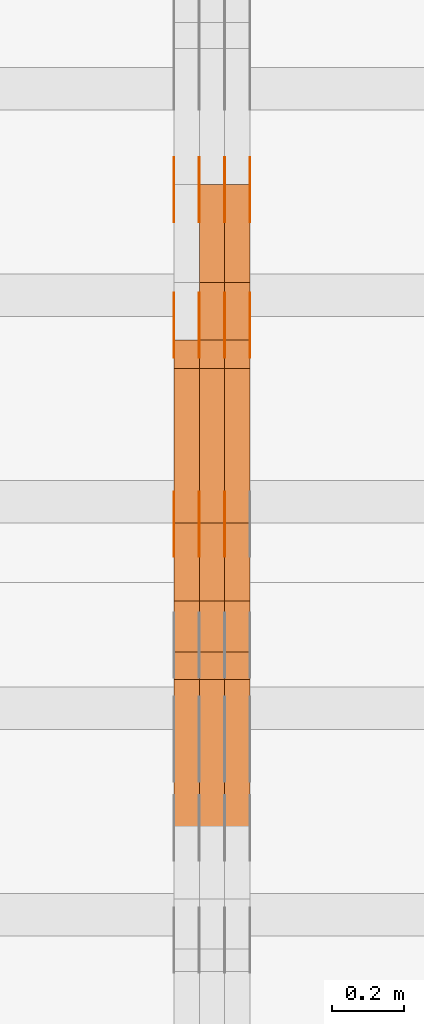
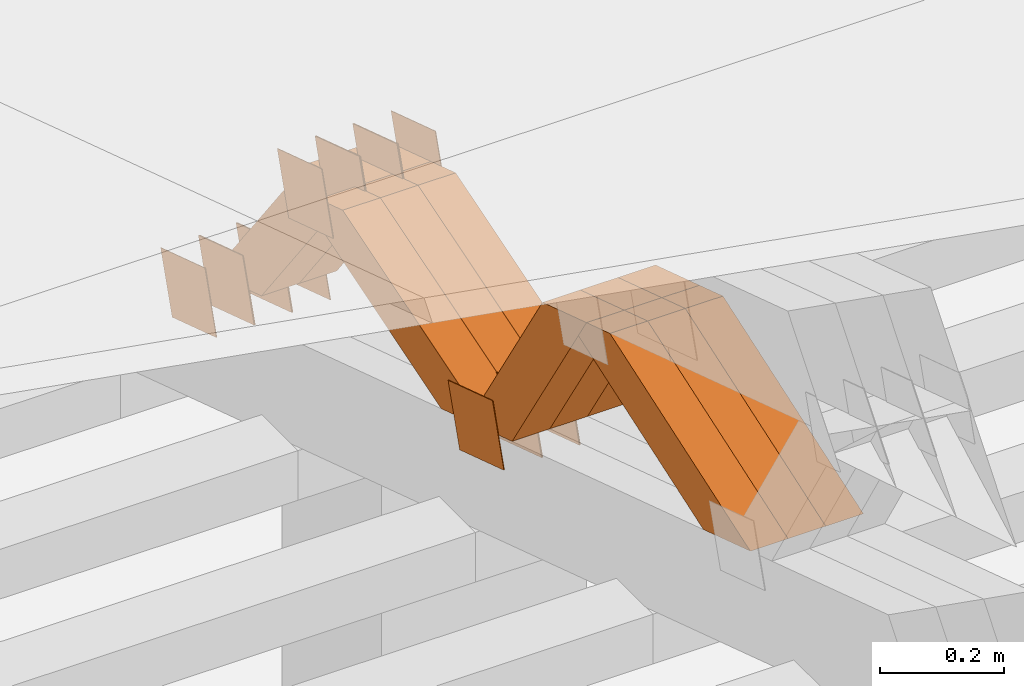
# One storey, part 232 of 385: 28 proxies.
"""IFC2X3 building model written with IfcOpenShell, lengths in millimetres."""

from ifc_helpers import new_model, entity, si_unit, converted_unit, derived_unit, direction, frame, origin, place, context, subcontext, project, spatial, polyline, outline, extrude, source, transform, mapped, material, type_object, type_shapes, element, save


model = new_model("IFC2X3")

# Units and contexts
model_context = context("Model", 3, precision=0.01, world=origin(), true_north=direction((6.12303176911189e-17, 1.0)))
body_context = subcontext(model_context, "Body", "Model", "MODEL_VIEW")
ifc_project = project(units=[si_unit("LENGTHUNIT", "METRE", prefix="MILLI"), si_unit("AREAUNIT", "SQUARE_METRE"), si_unit("VOLUMEUNIT", "CUBIC_METRE"), converted_unit("PLANEANGLEUNIT", "DEGREE", entity("IfcRatioMeasure", 0.0174532925199433), si_unit("PLANEANGLEUNIT", "RADIAN"), dimensions=[0, 0, 0, 0, 0, 0, 0]), si_unit("MASSUNIT", "GRAM", prefix="KILO"), derived_unit("MASSDENSITYUNIT", [(si_unit("MASSUNIT", "GRAM", prefix="KILO"), 1), (si_unit("LENGTHUNIT", "METRE"), -3)]), si_unit("TIMEUNIT", "SECOND"), si_unit("FREQUENCYUNIT", "HERTZ"), si_unit("THERMODYNAMICTEMPERATUREUNIT", "DEGREE_CELSIUS"), derived_unit("THERMALTRANSMITTANCEUNIT", [(si_unit("MASSUNIT", "GRAM", prefix="KILO"), 1), (si_unit("THERMODYNAMICTEMPERATUREUNIT", "KELVIN"), -1), (si_unit("TIMEUNIT", "SECOND"), -3)]), derived_unit("VOLUMETRICFLOWRATEUNIT", [(si_unit("LENGTHUNIT", "METRE"), 3), (si_unit("TIMEUNIT", "SECOND"), -1)]), si_unit("ELECTRICCURRENTUNIT", "AMPERE"), si_unit("ELECTRICVOLTAGEUNIT", "VOLT"), si_unit("POWERUNIT", "WATT"), si_unit("FORCEUNIT", "NEWTON", prefix="KILO"), si_unit("ILLUMINANCEUNIT", "LUX"), si_unit("LUMINOUSFLUXUNIT", "LUMEN"), si_unit("LUMINOUSINTENSITYUNIT", "CANDELA"), derived_unit("USERDEFINED", [(si_unit("MASSUNIT", "GRAM", prefix="KILO"), -1), (si_unit("LENGTHUNIT", "METRE"), -2), (si_unit("TIMEUNIT", "SECOND"), 3), (si_unit("LUMINOUSFLUXUNIT", "LUMEN"), 1)]), derived_unit("LINEARVELOCITYUNIT", [(si_unit("LENGTHUNIT", "METRE"), 1), (si_unit("TIMEUNIT", "SECOND"), -1)]), si_unit("PRESSUREUNIT", "PASCAL"), derived_unit("USERDEFINED", [(si_unit("LENGTHUNIT", "METRE"), -2), (si_unit("MASSUNIT", "GRAM", prefix="KILO"), 1), (si_unit("TIMEUNIT", "SECOND"), -2)])], contexts=[model_context])

# Site, building, storey
site_placement = place(None, origin())
site = spatial("IfcSite", under=ifc_project, at=site_placement, CompositionType="ELEMENT")
building_placement = place(site_placement, origin())
building = spatial("IfcBuilding", under=site, at=building_placement, CompositionType="ELEMENT")
storey_placement = place(building_placement, origin())
storey = spatial("IfcBuildingStorey", under=building, at=storey_placement, Name="Default", CompositionType="ELEMENT", Elevation=0.0)

# Proxies
ifc_material_1 = material(Name="IfcSurfaceStyle #375771")
building_element_proxy_type_1 = type_object("IfcBuildingElementProxyType", PredefinedType="NOTDEFINED", material=ifc_material_1)
shared_shape_1 = source(origin(), body_context, "Body", "SweptSolid", [
    extrude(outline(polyline([(-74.9998794200132, -59.999984515643), (74.9998565677174, -59.999984515643), (74.9998794200123, 59.999984515643), (-74.9998565677165, 59.999984515643), (-74.9998794200132, -59.999984515643)])), frame((75.0002235343086, 60.0000596852268, 0.0), z_axis=(0.0, 0.0, 1.0), x_axis=(-1.0, 0.0, 0.0)), (0.0, 0.0, 1.0), 1.3),
])
type_shapes(building_element_proxy_type_1, [shared_shape_1])
proxy_1_placement = place(building_placement, frame((30315.0, 20956.2317725846, 1832.75404405346), z_axis=(-1.0, 0.0, 0.0), x_axis=(0.0, -0.951056516295124, 0.309016994375039)))
element("IfcBuildingElementProxy", 1, at=proxy_1_placement, inside=storey, type_object=building_element_proxy_type_1, material=ifc_material_1, context=body_context, shape_type="MappedRepresentation", body=[
    mapped(shared_shape_1, transform((0.0, 0.0, 0.0), scale=1.0)),
])
ifc_material_2 = material(Name="IfcSurfaceStyle #375714")
building_element_proxy_type_2 = type_object("IfcBuildingElementProxyType", PredefinedType="NOTDEFINED", material=ifc_material_2)
shared_shape_2 = source(origin(), body_context, "Body", "SweptSolid", [
    extrude(outline(polyline([(-74.9998794200132, -59.999984515643), (74.9998565677174, -59.999984515643), (74.9998794200123, 59.999984515643), (-74.9998565677165, 59.999984515643), (-74.9998794200132, -59.999984515643)])), frame((75.0002235343086, 60.0000596852268, 0.0), z_axis=(0.0, 0.0, 1.0), x_axis=(-1.0, 0.0, 0.0)), (0.0, 0.0, 1.0), 1.3),
])
type_shapes(building_element_proxy_type_2, [shared_shape_2])
proxy_2_placement = place(building_placement, frame((30316.3, 20956.2317725846, 1832.75404405346), z_axis=(-1.0, 0.0, 0.0), x_axis=(0.0, -0.951056516295124, 0.309016994375039)))
element("IfcBuildingElementProxy", 2, at=proxy_2_placement, inside=storey, type_object=building_element_proxy_type_2, material=ifc_material_2, context=body_context, shape_type="MappedRepresentation", body=[
    mapped(shared_shape_2, transform((0.0, 0.0, 0.0), scale=1.0)),
])
ifc_material_3 = material(Name="IfcSurfaceStyle #375657")
building_element_proxy_type_3 = type_object("IfcBuildingElementProxyType", PredefinedType="NOTDEFINED", material=ifc_material_3)
shared_shape_3 = source(origin(), body_context, "Body", "SweptSolid", [
    extrude(outline(polyline([(-74.9998794200132, -59.999984515643), (74.9998565677174, -59.999984515643), (74.9998794200123, 59.999984515643), (-74.9998565677165, 59.999984515643), (-74.9998794200132, -59.999984515643)])), frame((75.0002235343086, 60.0000596852268, 0.0), z_axis=(0.0, 0.0, 1.0), x_axis=(-1.0, 0.0, 0.0)), (0.0, 0.0, 1.0), 1.29999999999999),
])
type_shapes(building_element_proxy_type_3, [shared_shape_3])
proxy_3_placement = place(building_placement, frame((30245.0, 20956.2317725846, 1832.75404405346), z_axis=(-1.0, 0.0, 0.0), x_axis=(0.0, -0.951056516295124, 0.309016994375039)))
element("IfcBuildingElementProxy", 3, at=proxy_3_placement, inside=storey, type_object=building_element_proxy_type_3, material=ifc_material_3, context=body_context, shape_type="MappedRepresentation", body=[
    mapped(shared_shape_3, transform((0.0, 0.0, 0.0), scale=1.0)),
])
ifc_material_4 = material(Name="IfcSurfaceStyle #375600")
building_element_proxy_type_4 = type_object("IfcBuildingElementProxyType", PredefinedType="NOTDEFINED", material=ifc_material_4)
shared_shape_4 = source(origin(), body_context, "Body", "SweptSolid", [
    extrude(outline(polyline([(-74.9998794200132, -59.999984515643), (74.9998565677174, -59.999984515643), (74.9998794200123, 59.999984515643), (-74.9998565677165, 59.999984515643), (-74.9998794200132, -59.999984515643)])), frame((75.0002235343086, 60.0000596852268, 0.0), z_axis=(0.0, 0.0, 1.0), x_axis=(-1.0, 0.0, 0.0)), (0.0, 0.0, 1.0), 1.29999999999999),
])
type_shapes(building_element_proxy_type_4, [shared_shape_4])
proxy_4_placement = place(building_placement, frame((30246.3, 20956.2317725846, 1832.75404405346), z_axis=(-1.0, 0.0, 0.0), x_axis=(0.0, -0.951056516295124, 0.309016994375039)))
element("IfcBuildingElementProxy", 4, at=proxy_4_placement, inside=storey, type_object=building_element_proxy_type_4, material=ifc_material_4, context=body_context, shape_type="MappedRepresentation", body=[
    mapped(shared_shape_4, transform((0.0, 0.0, 0.0), scale=1.0)),
])
ifc_material_5 = material(Name="IfcSurfaceStyle #375543")
building_element_proxy_type_5 = type_object("IfcBuildingElementProxyType", PredefinedType="NOTDEFINED", material=ifc_material_5)
shared_shape_5 = source(origin(), body_context, "Body", "SweptSolid", [
    extrude(outline(polyline([(-74.9998794200132, -59.999984515643), (74.9998565677174, -59.999984515643), (74.9998794200123, 59.999984515643), (-74.9998565677165, 59.999984515643), (-74.9998794200132, -59.999984515643)])), frame((75.0002235343086, 60.0000596852268, 0.0), z_axis=(0.0, 0.0, 1.0), x_axis=(-1.0, 0.0, 0.0)), (0.0, 0.0, 1.0), 1.29999999999999),
])
type_shapes(building_element_proxy_type_5, [shared_shape_5])
proxy_5_placement = place(building_placement, frame((30175.0, 20956.2317725846, 1832.75404405346), z_axis=(-1.0, 0.0, 0.0), x_axis=(0.0, -0.951056516295124, 0.309016994375039)))
element("IfcBuildingElementProxy", 5, at=proxy_5_placement, inside=storey, type_object=building_element_proxy_type_5, material=ifc_material_5, context=body_context, shape_type="MappedRepresentation", body=[
    mapped(shared_shape_5, transform((0.0, 0.0, 0.0), scale=1.0)),
])
ifc_material_6 = material(Name="IfcSurfaceStyle #375486")
building_element_proxy_type_6 = type_object("IfcBuildingElementProxyType", PredefinedType="NOTDEFINED", material=ifc_material_6)
shared_shape_6 = source(origin(), body_context, "Body", "SweptSolid", [
    extrude(outline(polyline([(-75.0001116115454, -60.0000599592451), (75.0000887592496, -60.0000599592451), (75.0001116115454, 60.0000599592451), (-75.0000887592496, 60.0000599592451), (-75.0001116115454, -60.0000599592451)])), frame((75.0001116115454, 60.0000599592451, 0.0), z_axis=(0.0, 0.0, 1.0), x_axis=(-1.0, 0.0, 0.0)), (0.0, 0.0, 1.0), 1.3),
])
type_shapes(building_element_proxy_type_6, [shared_shape_6])
proxy_6_placement = place(building_placement, frame((30386.3, 21881.0815195707, 1532.2522473242), z_axis=(-1.0, 0.0, 0.0), x_axis=(0.0, -0.951056516295124, 0.309016994375039)))
element("IfcBuildingElementProxy", 6, at=proxy_6_placement, inside=storey, type_object=building_element_proxy_type_6, material=ifc_material_6, context=body_context, shape_type="MappedRepresentation", body=[
    mapped(shared_shape_6, transform((0.0, 0.0, 0.0), scale=1.0)),
])
ifc_material_7 = material(Name="IfcSurfaceStyle #375429")
building_element_proxy_type_7 = type_object("IfcBuildingElementProxyType", PredefinedType="NOTDEFINED", material=ifc_material_7)
shared_shape_7 = source(origin(), body_context, "Body", "SweptSolid", [
    extrude(outline(polyline([(-75.0001116115454, -60.0000599592451), (75.0000887592496, -60.0000599592451), (75.0001116115454, 60.0000599592451), (-75.0000887592496, 60.0000599592451), (-75.0001116115454, -60.0000599592451)])), frame((75.0001116115454, 60.0000599592451, 0.0), z_axis=(0.0, 0.0, 1.0), x_axis=(-1.0, 0.0, 0.0)), (0.0, 0.0, 1.0), 1.3),
])
type_shapes(building_element_proxy_type_7, [shared_shape_7])
proxy_7_placement = place(building_placement, frame((30315.0, 21881.0815195707, 1532.2522473242), z_axis=(-1.0, 0.0, 0.0), x_axis=(0.0, -0.951056516295124, 0.309016994375039)))
element("IfcBuildingElementProxy", 7, at=proxy_7_placement, inside=storey, type_object=building_element_proxy_type_7, material=ifc_material_7, context=body_context, shape_type="MappedRepresentation", body=[
    mapped(shared_shape_7, transform((0.0, 0.0, 0.0), scale=1.0)),
])
ifc_material_8 = material(Name="IfcSurfaceStyle #375372")
building_element_proxy_type_8 = type_object("IfcBuildingElementProxyType", PredefinedType="NOTDEFINED", material=ifc_material_8)
shared_shape_8 = source(origin(), body_context, "Body", "SweptSolid", [
    extrude(outline(polyline([(-75.0001116115454, -60.0000599592451), (75.0000887592496, -60.0000599592451), (75.0001116115454, 60.0000599592451), (-75.0000887592496, 60.0000599592451), (-75.0001116115454, -60.0000599592451)])), frame((75.0001116115454, 60.0000599592451, 0.0), z_axis=(0.0, 0.0, 1.0), x_axis=(-1.0, 0.0, 0.0)), (0.0, 0.0, 1.0), 1.3),
])
type_shapes(building_element_proxy_type_8, [shared_shape_8])
proxy_8_placement = place(building_placement, frame((30316.3, 21881.0815195707, 1532.2522473242), z_axis=(-1.0, 0.0, 0.0), x_axis=(0.0, -0.951056516295124, 0.309016994375039)))
element("IfcBuildingElementProxy", 8, at=proxy_8_placement, inside=storey, type_object=building_element_proxy_type_8, material=ifc_material_8, context=body_context, shape_type="MappedRepresentation", body=[
    mapped(shared_shape_8, transform((0.0, 0.0, 0.0), scale=1.0)),
])
ifc_material_9 = material(Name="IfcSurfaceStyle #375315")
building_element_proxy_type_9 = type_object("IfcBuildingElementProxyType", PredefinedType="NOTDEFINED", material=ifc_material_9)
shared_shape_9 = source(origin(), body_context, "Body", "SweptSolid", [
    extrude(outline(polyline([(-75.0001116115454, -60.0000599592451), (75.0000887592496, -60.0000599592451), (75.0001116115454, 60.0000599592451), (-75.0000887592496, 60.0000599592451), (-75.0001116115454, -60.0000599592451)])), frame((75.0001116115454, 60.0000599592451, 0.0), z_axis=(0.0, 0.0, 1.0), x_axis=(-1.0, 0.0, 0.0)), (0.0, 0.0, 1.0), 1.29999999999999),
])
type_shapes(building_element_proxy_type_9, [shared_shape_9])
proxy_9_placement = place(building_placement, frame((30245.0, 21881.0815195707, 1532.2522473242), z_axis=(-1.0, 0.0, 0.0), x_axis=(0.0, -0.951056516295124, 0.309016994375039)))
element("IfcBuildingElementProxy", 9, at=proxy_9_placement, inside=storey, type_object=building_element_proxy_type_9, material=ifc_material_9, context=body_context, shape_type="MappedRepresentation", body=[
    mapped(shared_shape_9, transform((0.0, 0.0, 0.0), scale=1.0)),
])
ifc_material_10 = material(Name="IfcSurfaceStyle #375258")
building_element_proxy_type_10 = type_object("IfcBuildingElementProxyType", PredefinedType="NOTDEFINED", material=ifc_material_10)
shared_shape_10 = source(origin(), body_context, "Body", "SweptSolid", [
    extrude(outline(polyline([(-75.0001116115454, -60.0000599592451), (75.0000887592496, -60.0000599592451), (75.0001116115454, 60.0000599592451), (-75.0000887592496, 60.0000599592451), (-75.0001116115454, -60.0000599592451)])), frame((75.0001116115454, 60.0000599592451, 0.0), z_axis=(0.0, 0.0, 1.0), x_axis=(-1.0, 0.0, 0.0)), (0.0, 0.0, 1.0), 1.29999999999999),
])
type_shapes(building_element_proxy_type_10, [shared_shape_10])
proxy_10_placement = place(building_placement, frame((30246.3, 21881.0815195707, 1532.2522473242), z_axis=(-1.0, 0.0, 0.0), x_axis=(0.0, -0.951056516295124, 0.309016994375039)))
element("IfcBuildingElementProxy", 10, at=proxy_10_placement, inside=storey, type_object=building_element_proxy_type_10, material=ifc_material_10, context=body_context, shape_type="MappedRepresentation", body=[
    mapped(shared_shape_10, transform((0.0, 0.0, 0.0), scale=1.0)),
])
ifc_material_11 = material(Name="IfcSurfaceStyle #375201")
building_element_proxy_type_11 = type_object("IfcBuildingElementProxyType", PredefinedType="NOTDEFINED", material=ifc_material_11)
shared_shape_11 = source(origin(), body_context, "Body", "SweptSolid", [
    extrude(outline(polyline([(-75.0001116115454, -60.0000599592451), (75.0000887592496, -60.0000599592451), (75.0001116115454, 60.0000599592451), (-75.0000887592496, 60.0000599592451), (-75.0001116115454, -60.0000599592451)])), frame((75.0001116115454, 60.0000599592451, 0.0), z_axis=(0.0, 0.0, 1.0), x_axis=(-1.0, 0.0, 0.0)), (0.0, 0.0, 1.0), 1.29999999999999),
])
type_shapes(building_element_proxy_type_11, [shared_shape_11])
proxy_11_placement = place(building_placement, frame((30175.0, 21881.0815195707, 1532.2522473242), z_axis=(-1.0, 0.0, 0.0), x_axis=(0.0, -0.951056516295124, 0.309016994375039)))
element("IfcBuildingElementProxy", 11, at=proxy_11_placement, inside=storey, type_object=building_element_proxy_type_11, material=ifc_material_11, context=body_context, shape_type="MappedRepresentation", body=[
    mapped(shared_shape_11, transform((0.0, 0.0, 0.0), scale=1.0)),
])
ifc_material_12 = material(Name="IfcSurfaceStyle #370014")
building_element_proxy_type_12 = type_object("IfcBuildingElementProxyType", PredefinedType="NOTDEFINED", material=ifc_material_12)
shared_shape_12 = source(origin(), body_context, "Body", "SweptSolid", [
    extrude(outline(polyline([(-74.9998794200064, -59.9999845156358), (74.9998565677224, -59.9999845156358), (74.9998794200064, 59.9999845156358), (-74.9998565677224, 59.9999845156358), (-74.9998794200064, -59.9999845156358)])), frame((74.9999765995044, 60.0000596852337, 0.0), z_axis=(0.0, 0.0, 1.0), x_axis=(-1.0, 0.0, 0.0)), (0.0, 0.0, 1.0), 1.3),
])
type_shapes(building_element_proxy_type_12, [shared_shape_12])
proxy_12_placement = place(building_placement, frame((30386.3, 21505.9776314857, 1954.5332951652), z_axis=(-1.0, 0.0, 0.0), x_axis=(0.0, -0.951056516295154, 0.309016994374948)))
element("IfcBuildingElementProxy", 12, at=proxy_12_placement, inside=storey, type_object=building_element_proxy_type_12, material=ifc_material_12, context=body_context, shape_type="MappedRepresentation", body=[
    mapped(shared_shape_12, transform((0.0, 0.0, 0.0), scale=1.0)),
])
ifc_material_13 = material(Name="IfcSurfaceStyle #369957")
building_element_proxy_type_13 = type_object("IfcBuildingElementProxyType", PredefinedType="NOTDEFINED", material=ifc_material_13)
shared_shape_13 = source(origin(), body_context, "Body", "SweptSolid", [
    extrude(outline(polyline([(-74.9998794200064, -59.9999845156358), (74.9998565677224, -59.9999845156358), (74.9998794200064, 59.9999845156358), (-74.9998565677224, 59.9999845156358), (-74.9998794200064, -59.9999845156358)])), frame((74.9999765995044, 60.0000596852337, 0.0), z_axis=(0.0, 0.0, 1.0), x_axis=(-1.0, 0.0, 0.0)), (0.0, 0.0, 1.0), 1.3),
])
type_shapes(building_element_proxy_type_13, [shared_shape_13])
proxy_13_placement = place(building_placement, frame((30315.0, 21505.9776314857, 1954.5332951652), z_axis=(-1.0, 0.0, 0.0), x_axis=(0.0, -0.951056516295154, 0.309016994374948)))
element("IfcBuildingElementProxy", 13, at=proxy_13_placement, inside=storey, type_object=building_element_proxy_type_13, material=ifc_material_13, context=body_context, shape_type="MappedRepresentation", body=[
    mapped(shared_shape_13, transform((0.0, 0.0, 0.0), scale=1.0)),
])
ifc_material_14 = material(Name="IfcSurfaceStyle #369900")
building_element_proxy_type_14 = type_object("IfcBuildingElementProxyType", PredefinedType="NOTDEFINED", material=ifc_material_14)
shared_shape_14 = source(origin(), body_context, "Body", "SweptSolid", [
    extrude(outline(polyline([(-74.9998794200064, -59.9999845156358), (74.9998565677224, -59.9999845156358), (74.9998794200064, 59.9999845156358), (-74.9998565677224, 59.9999845156358), (-74.9998794200064, -59.9999845156358)])), frame((74.9999765995044, 60.0000596852337, 0.0), z_axis=(0.0, 0.0, 1.0), x_axis=(-1.0, 0.0, 0.0)), (0.0, 0.0, 1.0), 1.3),
])
type_shapes(building_element_proxy_type_14, [shared_shape_14])
proxy_14_placement = place(building_placement, frame((30316.3, 21505.9776314857, 1954.5332951652), z_axis=(-1.0, 0.0, 0.0), x_axis=(0.0, -0.951056516295154, 0.309016994374948)))
element("IfcBuildingElementProxy", 14, at=proxy_14_placement, inside=storey, type_object=building_element_proxy_type_14, material=ifc_material_14, context=body_context, shape_type="MappedRepresentation", body=[
    mapped(shared_shape_14, transform((0.0, 0.0, 0.0), scale=1.0)),
])
ifc_material_15 = material(Name="IfcSurfaceStyle #369843")
building_element_proxy_type_15 = type_object("IfcBuildingElementProxyType", PredefinedType="NOTDEFINED", material=ifc_material_15)
shared_shape_15 = source(origin(), body_context, "Body", "SweptSolid", [
    extrude(outline(polyline([(-74.9998794200064, -59.9999845156358), (74.9998565677224, -59.9999845156358), (74.9998794200064, 59.9999845156358), (-74.9998565677224, 59.9999845156358), (-74.9998794200064, -59.9999845156358)])), frame((74.9999765995044, 60.0000596852337, 0.0), z_axis=(0.0, 0.0, 1.0), x_axis=(-1.0, 0.0, 0.0)), (0.0, 0.0, 1.0), 1.29999999999999),
])
type_shapes(building_element_proxy_type_15, [shared_shape_15])
proxy_15_placement = place(building_placement, frame((30245.0, 21505.9776314857, 1954.5332951652), z_axis=(-1.0, 0.0, 0.0), x_axis=(0.0, -0.951056516295154, 0.309016994374948)))
element("IfcBuildingElementProxy", 15, at=proxy_15_placement, inside=storey, type_object=building_element_proxy_type_15, material=ifc_material_15, context=body_context, shape_type="MappedRepresentation", body=[
    mapped(shared_shape_15, transform((0.0, 0.0, 0.0), scale=1.0)),
])
ifc_material_16 = material(Name="IfcSurfaceStyle #369786")
building_element_proxy_type_16 = type_object("IfcBuildingElementProxyType", PredefinedType="NOTDEFINED", material=ifc_material_16)
shared_shape_16 = source(origin(), body_context, "Body", "SweptSolid", [
    extrude(outline(polyline([(-74.9998794200064, -59.9999845156358), (74.9998565677224, -59.9999845156358), (74.9998794200064, 59.9999845156358), (-74.9998565677224, 59.9999845156358), (-74.9998794200064, -59.9999845156358)])), frame((74.9999765995044, 60.0000596852337, 0.0), z_axis=(0.0, 0.0, 1.0), x_axis=(-1.0, 0.0, 0.0)), (0.0, 0.0, 1.0), 1.29999999999999),
])
type_shapes(building_element_proxy_type_16, [shared_shape_16])
proxy_16_placement = place(building_placement, frame((30246.3, 21505.9776314857, 1954.5332951652), z_axis=(-1.0, 0.0, 0.0), x_axis=(0.0, -0.951056516295154, 0.309016994374948)))
element("IfcBuildingElementProxy", 16, at=proxy_16_placement, inside=storey, type_object=building_element_proxy_type_16, material=ifc_material_16, context=body_context, shape_type="MappedRepresentation", body=[
    mapped(shared_shape_16, transform((0.0, 0.0, 0.0), scale=1.0)),
])
ifc_material_17 = material(Name="IfcSurfaceStyle #369729")
building_element_proxy_type_17 = type_object("IfcBuildingElementProxyType", PredefinedType="NOTDEFINED", material=ifc_material_17)
shared_shape_17 = source(origin(), body_context, "Body", "SweptSolid", [
    extrude(outline(polyline([(-74.9998794200064, -59.9999845156358), (74.9998565677224, -59.9999845156358), (74.9998794200064, 59.9999845156358), (-74.9998565677224, 59.9999845156358), (-74.9998794200064, -59.9999845156358)])), frame((74.9999765995044, 60.0000596852337, 0.0), z_axis=(0.0, 0.0, 1.0), x_axis=(-1.0, 0.0, 0.0)), (0.0, 0.0, 1.0), 1.29999999999999),
])
type_shapes(building_element_proxy_type_17, [shared_shape_17])
proxy_17_placement = place(building_placement, frame((30175.0, 21505.9776314857, 1954.5332951652), z_axis=(-1.0, 0.0, 0.0), x_axis=(0.0, -0.951056516295154, 0.309016994374948)))
element("IfcBuildingElementProxy", 17, at=proxy_17_placement, inside=storey, type_object=building_element_proxy_type_17, material=ifc_material_17, context=body_context, shape_type="MappedRepresentation", body=[
    mapped(shared_shape_17, transform((0.0, 0.0, 0.0), scale=1.0)),
])
ifc_material_18 = material(Name="IfcSurfaceStyle #358566")
building_element_proxy_type_18 = type_object("IfcBuildingElementProxyType", Name="T1-W26 358564", PredefinedType="NOTDEFINED", material=ifc_material_18)
shared_shape_18 = source(origin(), body_context, "Body", "SweptSolid", [
    extrude(outline(polyline([(-339.390941716546, -47.5001331548025), (137.738864791781, -47.5001331548025), (201.272298560955, 6.02772073885038e-05), (212.703852542003, 47.5001030161988), (-212.324074178193, 47.5001030161988), (-339.390941716546, -47.5001331548025)])), frame((212.703852542003, 47.5001030161988, 0.0), z_axis=(0.0, 0.0, 1.0), x_axis=(-1.0, 0.0, 0.0)), (0.0, 0.0, 1.0), 70.0),
])
type_shapes(building_element_proxy_type_18, [shared_shape_18])
proxy_18_placement = place(building_placement, frame((30385.0, 20576.541015625, 2286.80981445313), z_axis=(-1.0, 0.0, 0.0), x_axis=(0.0, -0.946743816465327, -0.321987804093053)))
element("IfcBuildingElementProxy", 18, at=proxy_18_placement, inside=storey, type_object=building_element_proxy_type_18, material=ifc_material_18, Name="T1-W26", context=body_context, shape_type="MappedRepresentation", body=[
    mapped(shared_shape_18, transform((0.0, 0.0, 0.0), scale=1.0)),
])
ifc_material_19 = material(Name="IfcSurfaceStyle #358500")
building_element_proxy_type_19 = type_object("IfcBuildingElementProxyType", Name="T1-W26 358498", PredefinedType="NOTDEFINED", material=ifc_material_19)
shared_shape_19 = source(origin(), body_context, "Body", "SweptSolid", [
    extrude(outline(polyline([(-339.390941716546, -47.5001331548025), (137.738864791781, -47.5001331548025), (201.272298560955, 6.02772073885038e-05), (212.703852542003, 47.5001030161988), (-212.324074178193, 47.5001030161988), (-339.390941716546, -47.5001331548025)])), frame((212.703852542003, 47.5001030161988, 0.0), z_axis=(0.0, 0.0, 1.0), x_axis=(-1.0, 0.0, 0.0)), (0.0, 0.0, 1.0), 70.0),
])
type_shapes(building_element_proxy_type_19, [shared_shape_19])
proxy_19_placement = place(building_placement, frame((30315.0, 20576.541015625, 2286.80981445313), z_axis=(-1.0, 0.0, 0.0), x_axis=(0.0, -0.946743816465327, -0.321987804093053)))
element("IfcBuildingElementProxy", 19, at=proxy_19_placement, inside=storey, type_object=building_element_proxy_type_19, material=ifc_material_19, Name="T1-W26", context=body_context, shape_type="MappedRepresentation", body=[
    mapped(shared_shape_19, transform((0.0, 0.0, 0.0), scale=1.0)),
])
ifc_material_20 = material(Name="IfcSurfaceStyle #358434")
building_element_proxy_type_20 = type_object("IfcBuildingElementProxyType", Name="T1-W26 358432", PredefinedType="NOTDEFINED", material=ifc_material_20)
shared_shape_20 = source(origin(), body_context, "Body", "SweptSolid", [
    extrude(outline(polyline([(-339.390941716546, -47.5001331548025), (137.738864791781, -47.5001331548025), (201.272298560955, 6.02772073885038e-05), (212.703852542003, 47.5001030161988), (-212.324074178193, 47.5001030161988), (-339.390941716546, -47.5001331548025)])), frame((212.703852542003, 47.5001030161988, 0.0), z_axis=(0.0, 0.0, 1.0), x_axis=(-1.0, 0.0, 0.0)), (0.0, 0.0, 1.0), 70.0),
])
type_shapes(building_element_proxy_type_20, [shared_shape_20])
proxy_20_placement = place(building_placement, frame((30245.0, 20576.541015625, 2286.80981445313), z_axis=(-1.0, 0.0, 0.0), x_axis=(0.0, -0.946743816465327, -0.321987804093053)))
element("IfcBuildingElementProxy", 20, at=proxy_20_placement, inside=storey, type_object=building_element_proxy_type_20, material=ifc_material_20, Name="T1-W26", context=body_context, shape_type="MappedRepresentation", body=[
    mapped(shared_shape_20, transform((0.0, 0.0, 0.0), scale=1.0)),
])
ifc_material_21 = material(Name="IfcSurfaceStyle #358170")
building_element_proxy_type_21 = type_object("IfcBuildingElementProxyType", Name="T1-W29 358168", PredefinedType="NOTDEFINED", material=ifc_material_21)
shared_shape_21 = source(origin(), body_context, "Body", "SweptSolid", [
    extrude(outline(polyline([(-202.325994317059, -47.5000867467013), (200.714255560873, -47.5000867467013), (187.834128885383, 0.000593513395139059), (130.590899902046, 47.4997899900038), (-316.813290031243, 47.4997899900038), (-202.325994317059, -47.5000867467013)])), frame((200.714255560873, 47.5001935424745, 0.0), z_axis=(0.0, 0.0, 1.0), x_axis=(-1.0, 0.0, 0.0)), (0.0, 0.0, 1.0), 70.0),
])
type_shapes(building_element_proxy_type_21, [shared_shape_21])
proxy_21_placement = place(building_placement, frame((30385.0, 20827.0771193222, 1890.72342063252), z_axis=(-1.0, 0.0, 0.0), x_axis=(0.0, -0.534567451138397, 0.845125813227473)))
element("IfcBuildingElementProxy", 21, at=proxy_21_placement, inside=storey, type_object=building_element_proxy_type_21, material=ifc_material_21, Name="T1-W29", context=body_context, shape_type="MappedRepresentation", body=[
    mapped(shared_shape_21, transform((0.0, 0.0, 0.0), scale=1.0)),
])
ifc_material_22 = material(Name="IfcSurfaceStyle #358104")
building_element_proxy_type_22 = type_object("IfcBuildingElementProxyType", Name="T1-W29 358102", PredefinedType="NOTDEFINED", material=ifc_material_22)
shared_shape_22 = source(origin(), body_context, "Body", "SweptSolid", [
    extrude(outline(polyline([(-202.325994317059, -47.5000867467013), (200.714255560873, -47.5000867467013), (187.834128885383, 0.000593513395139059), (130.590899902046, 47.4997899900038), (-316.813290031243, 47.4997899900038), (-202.325994317059, -47.5000867467013)])), frame((200.714255560873, 47.5001935424745, 0.0), z_axis=(0.0, 0.0, 1.0), x_axis=(-1.0, 0.0, 0.0)), (0.0, 0.0, 1.0), 70.0),
])
type_shapes(building_element_proxy_type_22, [shared_shape_22])
proxy_22_placement = place(building_placement, frame((30315.0, 20827.0771193222, 1890.72342063252), z_axis=(-1.0, 0.0, 0.0), x_axis=(0.0, -0.534567451138397, 0.845125813227473)))
element("IfcBuildingElementProxy", 22, at=proxy_22_placement, inside=storey, type_object=building_element_proxy_type_22, material=ifc_material_22, Name="T1-W29", context=body_context, shape_type="MappedRepresentation", body=[
    mapped(shared_shape_22, transform((0.0, 0.0, 0.0), scale=1.0)),
])
ifc_material_23 = material(Name="IfcSurfaceStyle #358038")
building_element_proxy_type_23 = type_object("IfcBuildingElementProxyType", Name="T1-W29 358036", PredefinedType="NOTDEFINED", material=ifc_material_23)
shared_shape_23 = source(origin(), body_context, "Body", "SweptSolid", [
    extrude(outline(polyline([(-202.325994317059, -47.5000867467013), (200.714255560873, -47.5000867467013), (187.834128885383, 0.000593513395139059), (130.590899902046, 47.4997899900038), (-316.813290031243, 47.4997899900038), (-202.325994317059, -47.5000867467013)])), frame((200.714255560873, 47.5001935424745, 0.0), z_axis=(0.0, 0.0, 1.0), x_axis=(-1.0, 0.0, 0.0)), (0.0, 0.0, 1.0), 70.0),
])
type_shapes(building_element_proxy_type_23, [shared_shape_23])
proxy_23_placement = place(building_placement, frame((30245.0, 20827.0771193222, 1890.72342063252), z_axis=(-1.0, 0.0, 0.0), x_axis=(0.0, -0.534567451138397, 0.845125813227473)))
element("IfcBuildingElementProxy", 23, at=proxy_23_placement, inside=storey, type_object=building_element_proxy_type_23, material=ifc_material_23, Name="T1-W29", context=body_context, shape_type="MappedRepresentation", body=[
    mapped(shared_shape_23, transform((0.0, 0.0, 0.0), scale=1.0)),
])
ifc_material_24 = material(Name="IfcSurfaceStyle #357774")
building_element_proxy_type_24 = type_object("IfcBuildingElementProxyType", Name="T1-W20 357772", PredefinedType="NOTDEFINED", material=ifc_material_24)
shared_shape_24 = source(origin(), body_context, "Body", "SweptSolid", [
    extrude(outline(polyline([(-355.264945969921, -47.5000317999193), (141.064821099313, -47.5000317999193), (208.541978467889, 8.19311626391928e-05), (225.96877763549, 47.499990834338), (-220.31063123277, 47.4999908343379), (-355.264945969921, -47.5000317999193)])), frame((225.968921063481, 47.5000683592689, 0.0), z_axis=(0.0, 0.0, 1.0), x_axis=(-1.0, 0.0, 0.0)), (0.0, 0.0, 1.0), 70.0),
])
type_shapes(building_element_proxy_type_24, [shared_shape_24])
proxy_24_placement = place(building_placement, frame((30385.0, 21443.7472302196, 2007.54830804072), z_axis=(-1.0, 0.0, 0.0), x_axis=(0.0, -0.95556995517236, -0.29476441571515)))
element("IfcBuildingElementProxy", 24, at=proxy_24_placement, inside=storey, type_object=building_element_proxy_type_24, material=ifc_material_24, Name="T1-W20", context=body_context, shape_type="MappedRepresentation", body=[
    mapped(shared_shape_24, transform((0.0, 0.0, 0.0), scale=1.0)),
])
ifc_material_25 = material(Name="IfcSurfaceStyle #357708")
building_element_proxy_type_25 = type_object("IfcBuildingElementProxyType", Name="T1-W20 357706", PredefinedType="NOTDEFINED", material=ifc_material_25)
shared_shape_25 = source(origin(), body_context, "Body", "SweptSolid", [
    extrude(outline(polyline([(-355.264945969921, -47.5000317999193), (141.064821099313, -47.5000317999193), (208.541978467889, 8.19311626391928e-05), (225.96877763549, 47.499990834338), (-220.31063123277, 47.4999908343379), (-355.264945969921, -47.5000317999193)])), frame((225.968921063481, 47.5000683592689, 0.0), z_axis=(0.0, 0.0, 1.0), x_axis=(-1.0, 0.0, 0.0)), (0.0, 0.0, 1.0), 70.0),
])
type_shapes(building_element_proxy_type_25, [shared_shape_25])
proxy_25_placement = place(building_placement, frame((30315.0, 21443.7472302196, 2007.54830804072), z_axis=(-1.0, 0.0, 0.0), x_axis=(0.0, -0.95556995517236, -0.29476441571515)))
element("IfcBuildingElementProxy", 25, at=proxy_25_placement, inside=storey, type_object=building_element_proxy_type_25, material=ifc_material_25, Name="T1-W20", context=body_context, shape_type="MappedRepresentation", body=[
    mapped(shared_shape_25, transform((0.0, 0.0, 0.0), scale=1.0)),
])
ifc_material_26 = material(Name="IfcSurfaceStyle #357642")
building_element_proxy_type_26 = type_object("IfcBuildingElementProxyType", Name="T1-W20 357640", PredefinedType="NOTDEFINED", material=ifc_material_26)
shared_shape_26 = source(origin(), body_context, "Body", "SweptSolid", [
    extrude(outline(polyline([(-355.264945969921, -47.5000317999193), (141.064821099313, -47.5000317999193), (208.541978467889, 8.19311626391928e-05), (225.96877763549, 47.499990834338), (-220.31063123277, 47.4999908343379), (-355.264945969921, -47.5000317999193)])), frame((225.968921063481, 47.5000683592689, 0.0), z_axis=(0.0, 0.0, 1.0), x_axis=(-1.0, 0.0, 0.0)), (0.0, 0.0, 1.0), 70.0),
])
type_shapes(building_element_proxy_type_26, [shared_shape_26])
proxy_26_placement = place(building_placement, frame((30245.0, 21443.7472302196, 2007.54830804072), z_axis=(-1.0, 0.0, 0.0), x_axis=(0.0, -0.95556995517236, -0.29476441571515)))
element("IfcBuildingElementProxy", 26, at=proxy_26_placement, inside=storey, type_object=building_element_proxy_type_26, material=ifc_material_26, Name="T1-W20", context=body_context, shape_type="MappedRepresentation", body=[
    mapped(shared_shape_26, transform((0.0, 0.0, 0.0), scale=1.0)),
])
ifc_material_27 = material(Name="IfcSurfaceStyle #357378")
building_element_proxy_type_27 = type_object("IfcBuildingElementProxyType", Name="T1-W18 357376", PredefinedType="NOTDEFINED", material=ifc_material_27)
shared_shape_27 = source(origin(), body_context, "Body", "SweptSolid", [
    extrude(outline(polyline([(-221.504996322134, -47.4999929258616), (225.406467948779, -47.4999929258616), (211.663832468686, -0.000107703153482008), (143.08905281687, 47.5000467774384), (-358.6543569122, 47.5000467774384), (-221.504996322134, -47.4999929258616)])), frame((225.406576158364, 47.5000467774384, 0.0), z_axis=(0.0, 0.0, 1.0), x_axis=(-1.0, 0.0, 0.0)), (0.0, 0.0, 1.0), 70.0),
])
type_shapes(building_element_proxy_type_27, [shared_shape_27])
proxy_27_placement = place(building_placement, frame((30385.0, 21766.9513837803, 1583.13813361817), z_axis=(-1.0, 0.0, 0.0), x_axis=(0.0, -0.605858491298265, 0.795572428206126)))
element("IfcBuildingElementProxy", 27, at=proxy_27_placement, inside=storey, type_object=building_element_proxy_type_27, material=ifc_material_27, Name="T1-W18", context=body_context, shape_type="MappedRepresentation", body=[
    mapped(shared_shape_27, transform((0.0, 0.0, 0.0), scale=1.0)),
])
ifc_material_28 = material(Name="IfcSurfaceStyle #357312")
building_element_proxy_type_28 = type_object("IfcBuildingElementProxyType", Name="T1-W18 357310", PredefinedType="NOTDEFINED", material=ifc_material_28)
shared_shape_28 = source(origin(), body_context, "Body", "SweptSolid", [
    extrude(outline(polyline([(-221.504996322134, -47.4999929258616), (225.406467948779, -47.4999929258616), (211.663832468686, -0.000107703153482008), (143.08905281687, 47.5000467774384), (-358.6543569122, 47.5000467774384), (-221.504996322134, -47.4999929258616)])), frame((225.406576158364, 47.5000467774384, 0.0), z_axis=(0.0, 0.0, 1.0), x_axis=(-1.0, 0.0, 0.0)), (0.0, 0.0, 1.0), 70.0),
])
type_shapes(building_element_proxy_type_28, [shared_shape_28])
proxy_28_placement = place(building_placement, frame((30315.0, 21766.9513837803, 1583.13813361817), z_axis=(-1.0, 0.0, 0.0), x_axis=(0.0, -0.605858491298265, 0.795572428206126)))
element("IfcBuildingElementProxy", 28, at=proxy_28_placement, inside=storey, type_object=building_element_proxy_type_28, material=ifc_material_28, Name="T1-W18", context=body_context, shape_type="MappedRepresentation", body=[
    mapped(shared_shape_28, transform((0.0, 0.0, 0.0), scale=1.0)),
])

save(model, "model.ifc")
